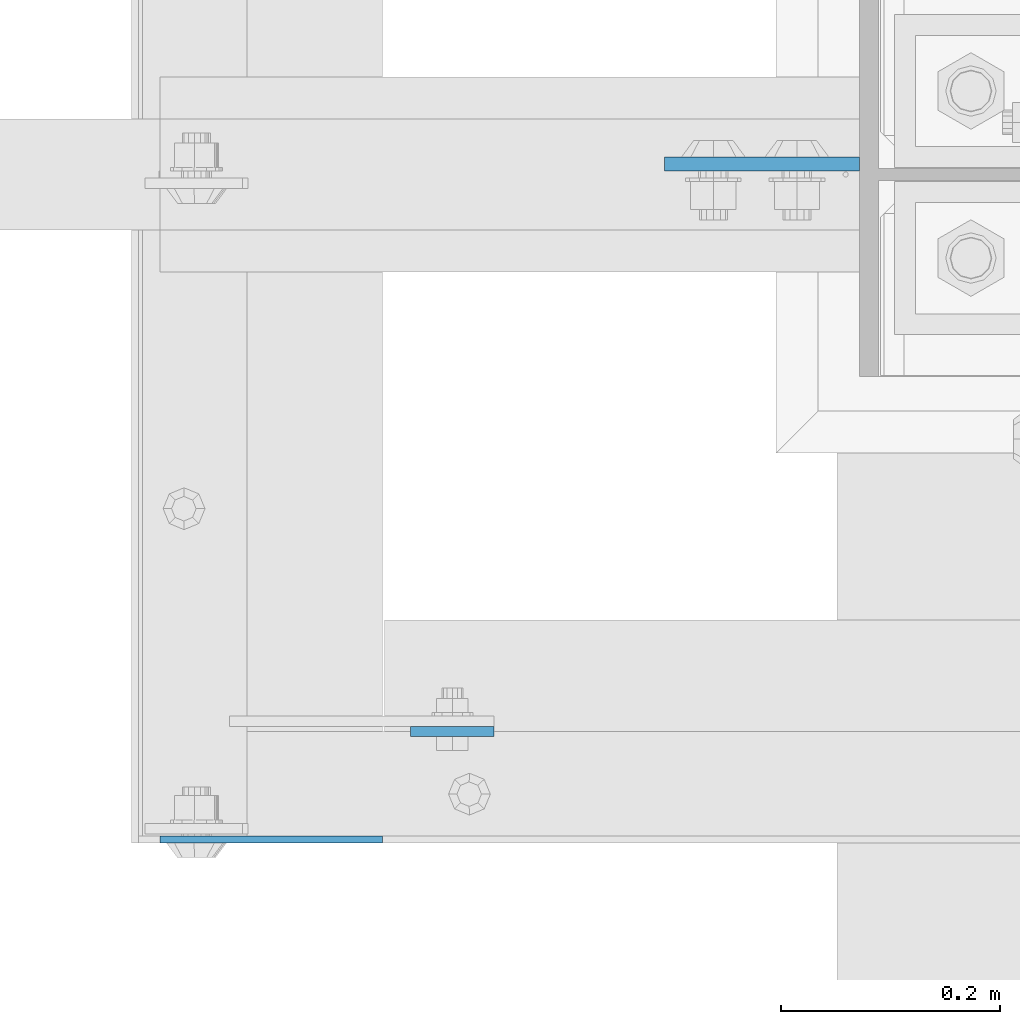
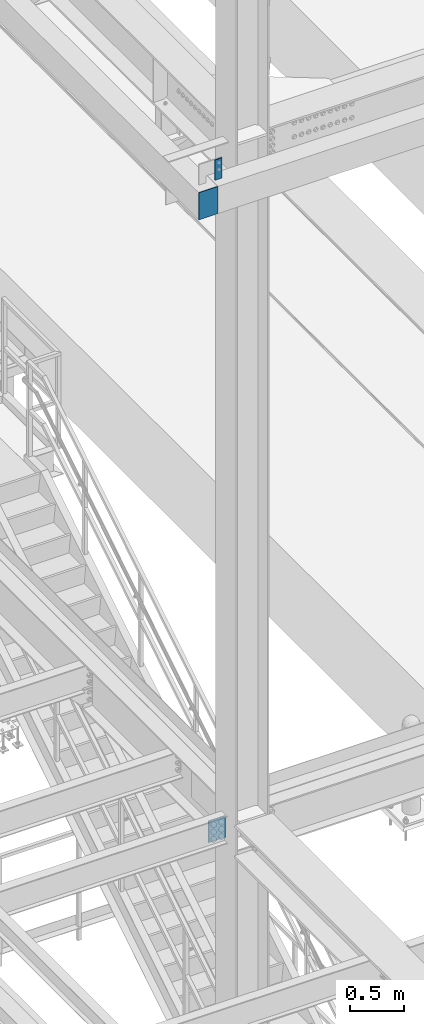
# One storey, part 1453 of 3843: 3 columns, 3 elements without a shape of their own.
"""IFC2X3 building model written with IfcOpenShell, lengths in millimetres."""

from ifc_helpers import new_model, si_unit, frame, origin_with_axes, place, context, subcontext, project, spatial, faceted_brep, material, type_object, element, aggregate, save


model = new_model("IFC2X3")

# Units and contexts
model_context = context("Model", 3, precision=1e-05, world=origin_with_axes())
body_context = subcontext(model_context, "Body", "Model", "MODEL_VIEW")
ifc_project = project(units=[si_unit("LENGTHUNIT", "METRE", prefix="MILLI"), si_unit("AREAUNIT", "SQUARE_METRE"), si_unit("VOLUMEUNIT", "CUBIC_METRE"), si_unit("MASSUNIT", "GRAM", prefix="KILO"), si_unit("TIMEUNIT", "SECOND"), si_unit("PLANEANGLEUNIT", "RADIAN"), si_unit("SOLIDANGLEUNIT", "STERADIAN"), si_unit("THERMODYNAMICTEMPERATUREUNIT", "DEGREE_CELSIUS"), si_unit("LUMINOUSINTENSITYUNIT", "LUMEN")], contexts=[model_context])

# Site, building, storey
site_placement = place(None, origin_with_axes())
site = spatial("IfcSite", under=ifc_project, at=site_placement, CompositionType="ELEMENT")
building_placement = place(site_placement, origin_with_axes())
building = spatial("IfcBuilding", under=site, at=building_placement, Name="Undefined", CompositionType="ELEMENT")
storey_placement = place(building_placement, origin_with_axes())
storey = spatial("IfcBuildingStorey", under=building, at=storey_placement, Name="Undefined", CompositionType="ELEMENT", Elevation=0.0)

# Assembly, column
assembly_1_placement = place(storey_placement, origin_with_axes())
assembly_1 = element("IfcElementAssembly", 1, at=assembly_1_placement, inside=storey, Name="GIRT", AssemblyPlace="NOTDEFINED", PredefinedType="RIGID_FRAME")
ifc_material = material(Name="STEEL/A572-50")
column_type_1 = type_object("IfcColumnType", PredefinedType="NOTDEFINED")
column_1_placement = place(assembly_1_placement, frame((35861.6250000001, 25009.475, 42062.4000000001), z_axis=(1.0, 0.0, 0.0), x_axis=(0.0, 0.0, 1.0)))
column_1 = element("IfcColumn", 2, at=column_1_placement, type_object=column_type_1, material=ifc_material, Name="PLATE", context=body_context, shape_type="Brep", body=[
    faceted_brep([(0.0, 3.17499999999927, -101.600000000006), (0.0, 3.17499999999927, 101.600000000006), (304.800000000003, 3.17499999999927, 101.600000000006), (304.800000000003, 3.17499999999927, -101.600000000006), (0.0, -3.17499999999927, 101.600000000006), (304.800000000003, -3.17499999999927, 101.600000000006), (0.0, -3.17499999999927, -101.600000000006), (304.800000000003, -3.17499999999927, -101.600000000006)], [[[0, 1, 2, 3]], [[1, 4, 5, 2]], [[4, 6, 7, 5]], [[6, 0, 3, 7]], [[5, 7, 3, 2]], [[6, 4, 1, 0]]]),
])
aggregate(assembly_1, [column_1])

assembly_2_placement = place(storey_placement, origin_with_axes())
assembly_2 = element("IfcElementAssembly", 3, at=assembly_2_placement, inside=storey, Name="GIRT", AssemblyPlace="NOTDEFINED", PredefinedType="RIGID_FRAME")
column_type_2 = type_object("IfcColumnType", PredefinedType="NOTDEFINED")
column_2_placement = place(assembly_2_placement, frame((36026.7250000001, 25107.9, 42367.2000000001), z_axis=(-1.0, 0.0, 0.0), x_axis=(0.0, 0.0, 1.0)))
column_2 = element("IfcColumn", 4, at=column_2_placement, type_object=column_type_2, material=ifc_material, Name="PLATE", context=body_context, shape_type="Brep", body=[
    faceted_brep([(0.0, 4.76250000000073, -38.0999999999985), (0.0, 4.76250000000073, 38.0999999999985), (228.599999999999, 4.76249999999709, 38.1000000000058), (228.599999999999, 4.76249999999709, -38.1000000000058), (0.0, -4.76250000000073, 38.0999999999985), (228.599999999999, -4.76249999999709, 38.1000000000058), (0.0, -4.76250000000073, -38.0999999999985), (228.599999999999, -4.76249999999709, -38.1000000000058)], [[[0, 1, 2, 3]], [[1, 4, 5, 2]], [[4, 6, 7, 5]], [[6, 0, 3, 7]], [[5, 7, 3, 2]], [[6, 4, 1, 0]]]),
])
aggregate(assembly_2, [column_2])

assembly_3_placement = place(storey_placement, origin_with_axes())
assembly_3 = element("IfcElementAssembly", 5, at=assembly_3_placement, inside=storey, Name="COLUMN", AssemblyPlace="NOTDEFINED", PredefinedType="RIGID_FRAME")
column_type_3 = type_object("IfcColumnType", PredefinedType="NOTDEFINED")
column_3_placement = place(assembly_3_placement, frame((36309.3, 25625.425, 34537.65), z_axis=(1.0, 0.0, 0.0), x_axis=(0.0, 0.0, 1.0)))
column_3 = element("IfcColumn", 6, at=column_3_placement, type_object=column_type_3, material=ifc_material, Name="PLATE", context=body_context, shape_type="Brep", body=[
    faceted_brep([(1.45519152283669e-11, 6.35000000000582, -88.8999999998996), (0.0, 6.34999999999854, 88.9000015258789), (241.300000000003, 6.34999999999854, 88.9000000000015), (241.300000000003, 6.34999999999854, -88.9000000000015), (0.0, -6.34999999999854, 88.9000015258789), (241.300000000003, -6.34999999999854, 88.9000000000015), (1.45519152283669e-11, -6.35000000000582, -88.8999999998996), (241.300000000003, -6.34999999999854, -88.9000000000015)], [[[0, 1, 2, 3]], [[1, 4, 5, 2]], [[4, 6, 7, 5]], [[6, 0, 3, 7]], [[5, 7, 3, 2]], [[6, 4, 1, 0]]]),
])
aggregate(assembly_3, [column_3])

save(model, "model.ifc")
